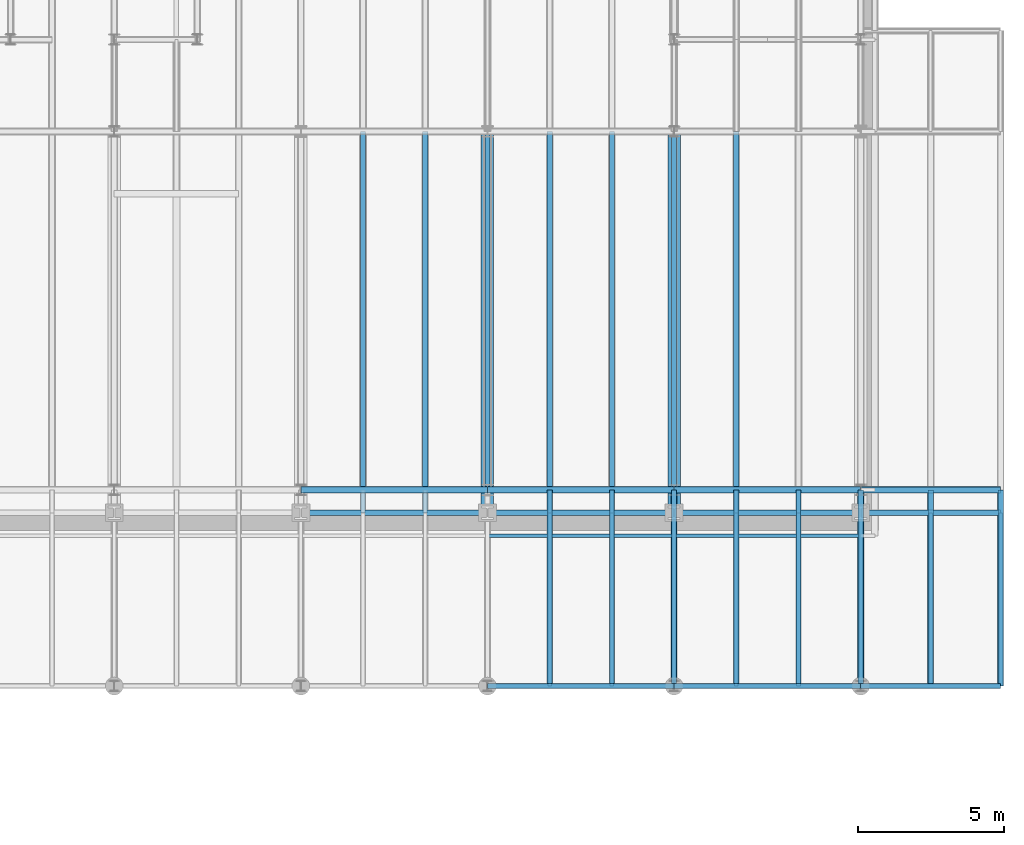
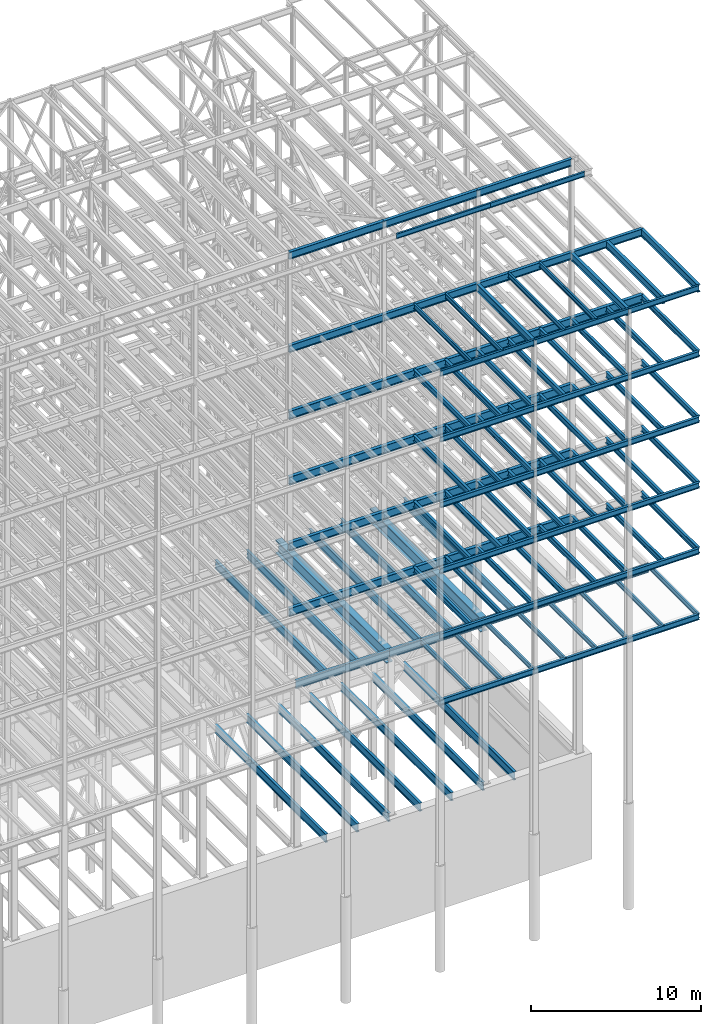
# One storey, part 139 of 150: 106 beams.
"""IFC2X3 building model written with IfcOpenShell, lengths in millimetres."""

from ifc_helpers import new_model, si_unit, frame, origin_with_axes, origin_2d_with_axis, place, context, subcontext, project, spatial, i_section, extrude, material, type_object, element, save


model = new_model("IFC2X3")

# Units and contexts
model_context = context("Model", 3, precision=1e-05, world=origin_with_axes())
body_context = subcontext(model_context, "Body", "Model", "MODEL_VIEW")
ifc_project = project(units=[si_unit("LENGTHUNIT", "METRE", prefix="MILLI"), si_unit("AREAUNIT", "SQUARE_METRE"), si_unit("VOLUMEUNIT", "CUBIC_METRE"), si_unit("MASSUNIT", "GRAM", prefix="KILO"), si_unit("TIMEUNIT", "SECOND"), si_unit("PLANEANGLEUNIT", "RADIAN"), si_unit("SOLIDANGLEUNIT", "STERADIAN"), si_unit("THERMODYNAMICTEMPERATUREUNIT", "DEGREE_CELSIUS"), si_unit("LUMINOUSINTENSITYUNIT", "LUMEN")], contexts=[model_context])

# Site, building, storey
site_placement = place(None, origin_with_axes())
site = spatial("IfcSite", under=ifc_project, at=site_placement, CompositionType="ELEMENT")
building_placement = place(site_placement, origin_with_axes())
building = spatial("IfcBuilding", under=site, at=building_placement, Name="Undefined", CompositionType="ELEMENT")
storey_placement = place(building_placement, origin_with_axes())
storey = spatial("IfcBuildingStorey", under=building, at=storey_placement, Name="Undefined", CompositionType="ELEMENT", Elevation=0.0)

# Beams
ifc_material = material(Name="STEEL/A992")
beam_type_1 = type_object("IfcBeamType", Name="W16X31", PredefinedType="NOTDEFINED")
beam_1_placement = place(storey_placement, frame((88595.2, 3454.4, 59005.7875), z_axis=(0.0, 0.0, 1.0), x_axis=(1.0, 0.0, 0.0)))
element("IfcBeam", 1, at=beam_1_placement, inside=storey, type_object=beam_type_1, material=ifc_material, Name="BEAM", ObjectType="W16X31", context=body_context, shape_type="SweptSolid", body=[
    extrude(i_section(OverallWidth=140.462, OverallDepth=403.225, WebThickness=6.3499, FlangeThickness=11.176, FilletRadius=17.399, at=origin_2d_with_axis()), frame((4800.60000000001, 0.0, 0.0), z_axis=(-1.0, 0.0, 0.0), x_axis=(0.0, -1.0, 0.0)), (0.0, 0.0, 1.0), 4800.60000000001),
])
beam_2_placement = place(storey_placement, frame((82194.4, 3454.4, 59005.7875), z_axis=(0.0, 0.0, 1.0), x_axis=(1.0, 0.0, 0.0)))
element("IfcBeam", 2, at=beam_2_placement, inside=storey, type_object=beam_type_1, material=ifc_material, Name="BEAM", ObjectType="W16X31", context=body_context, shape_type="SweptSolid", body=[
    extrude(i_section(OverallWidth=140.462, OverallDepth=403.225, WebThickness=6.3499, FlangeThickness=11.176, FilletRadius=17.399, at=origin_2d_with_axis()), frame((6400.80000000001, 0.0, 0.0), z_axis=(-1.0, 0.0, 0.0), x_axis=(0.0, -1.0, 0.0)), (0.0, 0.0, 1.0), 6400.80000000002),
])
beam_3_placement = place(storey_placement, frame((75793.6, 3454.4, 59005.7875), z_axis=(0.0, 0.0, 1.0), x_axis=(1.0, 0.0, 0.0)))
element("IfcBeam", 3, at=beam_3_placement, inside=storey, type_object=beam_type_1, material=ifc_material, Name="BEAM", ObjectType="W16X31", context=body_context, shape_type="SweptSolid", body=[
    extrude(i_section(OverallWidth=140.462, OverallDepth=403.225, WebThickness=6.3499, FlangeThickness=11.176, FilletRadius=17.399, at=origin_2d_with_axis()), frame((6400.80000000001, 0.0, 0.0), z_axis=(-1.0, 0.0, 0.0), x_axis=(0.0, -1.0, 0.0)), (0.0, 0.0, 1.0), 6400.79999999999),
])
beam_type_2 = type_object("IfcBeamType", Name="W24X68", PredefinedType="NOTDEFINED")
beam_4_placement = place(storey_placement, frame((88595.2, 10185.4, 54181.375), z_axis=(0.0, 0.0, 1.0), x_axis=(1.0, 0.0, 0.0)))
element("IfcBeam", 4, at=beam_4_placement, inside=storey, type_object=beam_type_2, material=ifc_material, Name="BEAM", ObjectType="W24X68", context=body_context, shape_type="SweptSolid", body=[
    extrude(i_section(OverallWidth=227.838, OverallDepth=603.25, WebThickness=11.1125, FlangeThickness=14.859, FilletRadius=23.2409, at=origin_2d_with_axis()), frame((4800.60000000001, 0.0, 0.0), z_axis=(-1.0, 0.0, 0.0), x_axis=(0.0, -1.0, 0.0)), (0.0, 0.0, 1.0), 4800.60000000001),
])
beam_5_placement = place(storey_placement, frame((82194.4, 10185.4, 54181.375), z_axis=(0.0, 0.0, 1.0), x_axis=(1.0, 0.0, 0.0)))
element("IfcBeam", 5, at=beam_5_placement, inside=storey, type_object=beam_type_2, material=ifc_material, Name="BEAM", ObjectType="W24X68", context=body_context, shape_type="SweptSolid", body=[
    extrude(i_section(OverallWidth=227.838, OverallDepth=603.25, WebThickness=11.1125, FlangeThickness=14.859, FilletRadius=23.2409, at=origin_2d_with_axis()), frame((6400.80000000001, 0.0, 0.0), z_axis=(-1.0, 0.0, 0.0), x_axis=(0.0, -1.0, 0.0)), (0.0, 0.0, 1.0), 6400.8),
])
beam_6_placement = place(storey_placement, frame((75793.6, 10185.4, 54181.375), z_axis=(0.0, 0.0, 1.0), x_axis=(1.0, 0.0, 0.0)))
element("IfcBeam", 6, at=beam_6_placement, inside=storey, type_object=beam_type_2, material=ifc_material, Name="BEAM", ObjectType="W24X68", context=body_context, shape_type="SweptSolid", body=[
    extrude(i_section(OverallWidth=227.838, OverallDepth=603.25, WebThickness=11.1125, FlangeThickness=14.859, FilletRadius=23.2409, at=origin_2d_with_axis()), frame((6400.80000000001, 0.0, 0.0), z_axis=(-1.0, 0.0, 0.0), x_axis=(0.0, -1.0, 0.0)), (0.0, 0.0, 1.0), 6400.79999999999),
])
for number, where, z_axis, x_axis, name in (
    (7, (69392.8, 10185.4, 54181.375), (0.0, 0.0, 1.0), (1.0, 0.0, 0.0), "BEAM"),
    (8, (82194.4, 10185.4, 49456.975), (0.0, 0.0, 1.0), (1.0, 0.0, 0.0), "BEAM"),
):
    element("IfcBeam", number, at=place(storey_placement, frame(where, z_axis=z_axis, x_axis=x_axis)), inside=storey, type_object=beam_type_2, material=ifc_material, Name=name, ObjectType="W24X68", context=body_context, shape_type="SweptSolid", body=[
        extrude(i_section(OverallWidth=227.838, OverallDepth=603.25, WebThickness=11.1125, FlangeThickness=14.859, FilletRadius=23.2409, at=origin_2d_with_axis()), frame((6400.80000000001, 0.0, 0.0), z_axis=(-1.0, 0.0, 0.0), x_axis=(0.0, -1.0, 0.0)), (0.0, 0.0, 1.0), 6400.8),
    ])
beam_7_placement = place(storey_placement, frame((75793.6, 10185.4, 49456.975), z_axis=(0.0, 0.0, 1.0), x_axis=(1.0, 0.0, 0.0)))
element("IfcBeam", 9, at=beam_7_placement, inside=storey, type_object=beam_type_2, material=ifc_material, Name="BEAM", ObjectType="W24X68", context=body_context, shape_type="SweptSolid", body=[
    extrude(i_section(OverallWidth=227.838, OverallDepth=603.25, WebThickness=11.1125, FlangeThickness=14.859, FilletRadius=23.2409, at=origin_2d_with_axis()), frame((6400.80000000001, 0.0, 0.0), z_axis=(-1.0, 0.0, 0.0), x_axis=(0.0, -1.0, 0.0)), (0.0, 0.0, 1.0), 6400.79999999999),
])
for number, where, z_axis, x_axis, name in (
    (10, (69392.8, 10185.4, 49456.975), (0.0, 0.0, 1.0), (1.0, 0.0, 0.0), "BEAM"),
    (11, (82194.4, 10185.4, 44732.575), (0.0, 0.0, 1.0), (1.0, 0.0, 0.0), "BEAM"),
):
    element("IfcBeam", number, at=place(storey_placement, frame(where, z_axis=z_axis, x_axis=x_axis)), inside=storey, type_object=beam_type_2, material=ifc_material, Name=name, ObjectType="W24X68", context=body_context, shape_type="SweptSolid", body=[
        extrude(i_section(OverallWidth=227.838, OverallDepth=603.25, WebThickness=11.1125, FlangeThickness=14.859, FilletRadius=23.2409, at=origin_2d_with_axis()), frame((6400.80000000001, 0.0, 0.0), z_axis=(-1.0, 0.0, 0.0), x_axis=(0.0, -1.0, 0.0)), (0.0, 0.0, 1.0), 6400.8),
    ])
beam_8_placement = place(storey_placement, frame((75793.6, 10185.4, 44732.575), z_axis=(0.0, 0.0, 1.0), x_axis=(1.0, 0.0, 0.0)))
element("IfcBeam", 12, at=beam_8_placement, inside=storey, type_object=beam_type_2, material=ifc_material, Name="BEAM", ObjectType="W24X68", context=body_context, shape_type="SweptSolid", body=[
    extrude(i_section(OverallWidth=227.838, OverallDepth=603.25, WebThickness=11.1125, FlangeThickness=14.859, FilletRadius=23.2409, at=origin_2d_with_axis()), frame((6400.80000000001, 0.0, 0.0), z_axis=(-1.0, 0.0, 0.0), x_axis=(0.0, -1.0, 0.0)), (0.0, 0.0, 1.0), 6400.79999999999),
])
for number, where, z_axis, x_axis, name in (
    (13, (69392.8, 10185.4, 44732.575), (0.0, 0.0, 1.0), (1.0, 0.0, 0.0), "BEAM"),
    (14, (82194.4, 10185.4, 40008.175), (0.0, 0.0, 1.0), (1.0, 0.0, 0.0), "BEAM"),
):
    element("IfcBeam", number, at=place(storey_placement, frame(where, z_axis=z_axis, x_axis=x_axis)), inside=storey, type_object=beam_type_2, material=ifc_material, Name=name, ObjectType="W24X68", context=body_context, shape_type="SweptSolid", body=[
        extrude(i_section(OverallWidth=227.838, OverallDepth=603.25, WebThickness=11.1125, FlangeThickness=14.859, FilletRadius=23.2409, at=origin_2d_with_axis()), frame((6400.80000000001, 0.0, 0.0), z_axis=(-1.0, 0.0, 0.0), x_axis=(0.0, -1.0, 0.0)), (0.0, 0.0, 1.0), 6400.8),
    ])
beam_9_placement = place(storey_placement, frame((75793.6, 10185.4, 40008.175), z_axis=(0.0, 0.0, 1.0), x_axis=(1.0, 0.0, 0.0)))
element("IfcBeam", 15, at=beam_9_placement, inside=storey, type_object=beam_type_2, material=ifc_material, Name="BEAM", ObjectType="W24X68", context=body_context, shape_type="SweptSolid", body=[
    extrude(i_section(OverallWidth=227.838, OverallDepth=603.25, WebThickness=11.1125, FlangeThickness=14.859, FilletRadius=23.2409, at=origin_2d_with_axis()), frame((6400.80000000001, 0.0, 0.0), z_axis=(-1.0, 0.0, 0.0), x_axis=(0.0, -1.0, 0.0)), (0.0, 0.0, 1.0), 6400.79999999999),
])
beam_10_placement = place(storey_placement, frame((69392.8, 10185.4, 40008.175), z_axis=(0.0, 0.0, 1.0), x_axis=(1.0, 0.0, 0.0)))
element("IfcBeam", 16, at=beam_10_placement, inside=storey, type_object=beam_type_2, material=ifc_material, Name="BEAM", ObjectType="W24X68", context=body_context, shape_type="SweptSolid", body=[
    extrude(i_section(OverallWidth=227.838, OverallDepth=603.25, WebThickness=11.1125, FlangeThickness=14.859, FilletRadius=23.2409, at=origin_2d_with_axis()), frame((6400.80000000001, 0.0, 0.0), z_axis=(-1.0, 0.0, 0.0), x_axis=(0.0, -1.0, 0.0)), (0.0, 0.0, 1.0), 6400.8),
])
beam_type_3 = type_object("IfcBeamType", Name="W14X22", PredefinedType="NOTDEFINED")
beam_11_placement = place(storey_placement, frame((82194.4, 8610.6, 65738.375), z_axis=(0.0, 0.0, 1.0), x_axis=(1.0, 0.0, 0.0)))
element("IfcBeam", 17, at=beam_11_placement, inside=storey, type_object=beam_type_3, material=ifc_material, Name="BEAM", ObjectType="W14X22", context=body_context, shape_type="SweptSolid", body=[
    extrude(i_section(OverallWidth=127.0, OverallDepth=349.25, WebThickness=6.3499, FlangeThickness=8.509, FilletRadius=18.4785, at=origin_2d_with_axis()), frame((6400.80000000001, 0.0, 0.0), z_axis=(-1.0, 0.0, 0.0), x_axis=(0.0, -1.0, 0.0)), (0.0, 0.0, 1.0), 6400.80000000002),
])
beam_12_placement = place(storey_placement, frame((75793.6, 8610.6, 65738.375), z_axis=(0.0, 0.0, 1.0), x_axis=(1.0, 0.0, 0.0)))
element("IfcBeam", 18, at=beam_12_placement, inside=storey, type_object=beam_type_3, material=ifc_material, Name="BEAM", ObjectType="W14X22", context=body_context, shape_type="SweptSolid", body=[
    extrude(i_section(OverallWidth=127.0, OverallDepth=349.25, WebThickness=6.3499, FlangeThickness=8.509, FilletRadius=18.4785, at=origin_2d_with_axis()), frame((6400.80000000001, 0.0, 0.0), z_axis=(-1.0, 0.0, 0.0), x_axis=(0.0, -1.0, 0.0)), (0.0, 0.0, 1.0), 6400.79999999999),
])
for number, where, z_axis, x_axis, name in (
    (19, (86461.6, 3454.4, 59032.775), (0.0, 0.0, 1.0), (0.0, 1.0, 0.0), "BEAM"),
    (20, (84328.0, 3454.4, 59032.775), (0.0, 0.0, 1.0), (0.0, 1.0, 0.0), "BEAM"),
    (21, (80060.8, 3454.4, 59032.775), (0.0, 0.0, 1.0), (0.0, 1.0, 0.0), "BEAM"),
    (22, (77927.2, 3454.4, 59032.775), (0.0, 0.0, 1.0), (0.0, 1.0, 0.0), "BEAM"),
):
    element("IfcBeam", number, at=place(storey_placement, frame(where, z_axis=z_axis, x_axis=x_axis)), inside=storey, type_object=beam_type_3, material=ifc_material, Name=name, ObjectType="W14X22", context=body_context, shape_type="SweptSolid", body=[
        extrude(i_section(OverallWidth=127.0, OverallDepth=349.25, WebThickness=6.3499, FlangeThickness=8.509, FilletRadius=18.4785, at=origin_2d_with_axis()), frame((6731.0, 0.0, 0.0), z_axis=(-1.0, 0.0, 0.0), x_axis=(0.0, -1.0, 0.0)), (0.0, 0.0, 1.0), 6731.0),
    ])
for number, where, z_axis, x_axis, name in (
    (23, (93395.8, 3454.4, 35410.775), (0.0, 0.0, 1.0), (0.0, 1.0, 0.0), "BEAM"),
    (24, (90995.5, 3454.4, 35410.775), (0.0, 0.0, 1.0), (0.0, 1.0, 0.0), "BEAM"),
    (25, (88595.2, 3454.4, 35410.775), (0.0, 0.0, 1.0), (0.0, 1.0, 0.0), "BEAM"),
    (26, (86461.6, 3454.4, 35410.775), (0.0, 0.0, 1.0), (0.0, 1.0, 0.0), "BEAM"),
    (27, (84328.0, 3454.4, 35410.775), (0.0, 0.0, 1.0), (0.0, 1.0, 0.0), "BEAM"),
    (28, (82194.4, 3454.4, 35410.775), (0.0, 0.0, 1.0), (0.0, 1.0, 0.0), "BEAM"),
    (29, (80060.8, 3454.4, 35410.775), (0.0, 0.0, 1.0), (0.0, 1.0, 0.0), "BEAM"),
    (30, (77927.2, 3454.4, 35410.775), (0.0, 0.0, 1.0), (0.0, 1.0, 0.0), "BEAM"),
):
    element("IfcBeam", number, at=place(storey_placement, frame(where, z_axis=z_axis, x_axis=x_axis)), inside=storey, type_object=beam_type_3, material=ifc_material, Name=name, ObjectType="W14X22", context=body_context, shape_type="SweptSolid", body=[
        extrude(i_section(OverallWidth=127.0, OverallDepth=349.25, WebThickness=6.3499, FlangeThickness=8.509, FilletRadius=18.4785, at=origin_2d_with_axis()), frame((5943.6, 0.0, 0.0), z_axis=(-1.0, 0.0, 0.0), x_axis=(0.0, -1.0, 0.0)), (0.0, 0.0, 1.0), 5943.6),
    ])
beam_type_4 = type_object("IfcBeamType", Name="W21X55", PredefinedType="NOTDEFINED")
beam_13_placement = place(storey_placement, frame((82194.4, 10185.4, 65649.475), z_axis=(0.0, 0.0, 1.0), x_axis=(1.0, 0.0, 0.0)))
element("IfcBeam", 31, at=beam_13_placement, inside=storey, type_object=beam_type_4, material=ifc_material, Name="BEAM", ObjectType="W21X55", context=body_context, shape_type="SweptSolid", body=[
    extrude(i_section(OverallWidth=208.788, OverallDepth=527.05, WebThickness=9.5, FlangeThickness=13.2588, FilletRadius=16.8624, at=origin_2d_with_axis()), frame((6400.80000000001, 0.0, 0.0), z_axis=(-1.0, 0.0, 0.0), x_axis=(0.0, -1.0, 0.0)), (0.0, 0.0, 1.0), 6400.80000000002),
])
beam_14_placement = place(storey_placement, frame((75793.6, 10185.4, 65649.475), z_axis=(0.0, 0.0, 1.0), x_axis=(1.0, 0.0, 0.0)))
element("IfcBeam", 32, at=beam_14_placement, inside=storey, type_object=beam_type_4, material=ifc_material, Name="BEAM", ObjectType="W21X55", context=body_context, shape_type="SweptSolid", body=[
    extrude(i_section(OverallWidth=208.788, OverallDepth=527.05, WebThickness=9.5, FlangeThickness=13.2588, FilletRadius=16.8624, at=origin_2d_with_axis()), frame((6400.80000000001, 0.0, 0.0), z_axis=(-1.0, 0.0, 0.0), x_axis=(0.0, -1.0, 0.0)), (0.0, 0.0, 1.0), 6400.79999999999),
])
beam_15_placement = place(storey_placement, frame((69392.8, 10185.4, 65649.475), z_axis=(0.0, 0.0, 1.0), x_axis=(1.0, 0.0, 0.0)))
element("IfcBeam", 33, at=beam_15_placement, inside=storey, type_object=beam_type_4, material=ifc_material, Name="BEAM", ObjectType="W21X55", context=body_context, shape_type="SweptSolid", body=[
    extrude(i_section(OverallWidth=208.788, OverallDepth=527.05, WebThickness=9.5, FlangeThickness=13.2588, FilletRadius=16.8624, at=origin_2d_with_axis()), frame((6400.80000000001, 0.0, 0.0), z_axis=(-1.0, 0.0, 0.0), x_axis=(0.0, -1.0, 0.0)), (0.0, 0.0, 1.0), 6400.80000000002),
])
beam_16_placement = place(storey_placement, frame((88595.2, 10185.4, 58943.875), z_axis=(0.0, 0.0, 1.0), x_axis=(1.0, 0.0, 0.0)))
element("IfcBeam", 34, at=beam_16_placement, inside=storey, type_object=beam_type_4, material=ifc_material, Name="BEAM", ObjectType="W21X55", context=body_context, shape_type="SweptSolid", body=[
    extrude(i_section(OverallWidth=208.788, OverallDepth=527.05, WebThickness=9.5, FlangeThickness=13.2588, FilletRadius=16.8624, at=origin_2d_with_axis()), frame((4800.60000000001, 0.0, 0.0), z_axis=(-1.0, 0.0, 0.0), x_axis=(0.0, -1.0, 0.0)), (0.0, 0.0, 1.0), 4800.60000000001),
])
for number, where, z_axis, x_axis, name in (
    (35, (93395.8, 3454.4, 58943.875), (0.0, 0.0, 1.0), (0.0, 1.0, 0.0), "BEAM"),
    (36, (90995.5, 3454.4, 58943.875), (0.0, 0.0, 1.0), (0.0, 1.0, 0.0), "BEAM"),
    (37, (88595.2, 3454.4, 58943.875), (0.0, 0.0, 1.0), (0.0, 1.0, 0.0), "BEAM"),
):
    element("IfcBeam", number, at=place(storey_placement, frame(where, z_axis=z_axis, x_axis=x_axis)), inside=storey, type_object=beam_type_4, material=ifc_material, Name=name, ObjectType="W21X55", context=body_context, shape_type="SweptSolid", body=[
        extrude(i_section(OverallWidth=208.788, OverallDepth=527.05, WebThickness=9.5, FlangeThickness=13.2588, FilletRadius=16.8624, at=origin_2d_with_axis()), frame((6731.0, 0.0, 0.0), z_axis=(-1.0, 0.0, 0.0), x_axis=(0.0, -1.0, 0.0)), (0.0, 0.0, 1.0), 6731.0),
    ])
beam_17_placement = place(storey_placement, frame((82194.4, 10185.4, 58943.875), z_axis=(0.0, 0.0, 1.0), x_axis=(1.0, 0.0, 0.0)))
element("IfcBeam", 38, at=beam_17_placement, inside=storey, type_object=beam_type_4, material=ifc_material, Name="BEAM", ObjectType="W21X55", context=body_context, shape_type="SweptSolid", body=[
    extrude(i_section(OverallWidth=208.788, OverallDepth=527.05, WebThickness=9.5, FlangeThickness=13.2588, FilletRadius=16.8624, at=origin_2d_with_axis()), frame((6400.80000000001, 0.0, 0.0), z_axis=(-1.0, 0.0, 0.0), x_axis=(0.0, -1.0, 0.0)), (0.0, 0.0, 1.0), 6400.80000000002),
])
beam_18_placement = place(storey_placement, frame((82194.4, 3454.4, 58943.875), z_axis=(0.0, 0.0, 1.0), x_axis=(0.0, 1.0, 0.0)))
element("IfcBeam", 39, at=beam_18_placement, inside=storey, type_object=beam_type_4, material=ifc_material, Name="BEAM", ObjectType="W21X55", context=body_context, shape_type="SweptSolid", body=[
    extrude(i_section(OverallWidth=208.788, OverallDepth=527.05, WebThickness=9.5, FlangeThickness=13.2588, FilletRadius=16.8624, at=origin_2d_with_axis()), frame((6731.0, 0.0, 0.0), z_axis=(-1.0, 0.0, 0.0), x_axis=(0.0, -1.0, 0.0)), (0.0, 0.0, 1.0), 6731.0),
])
beam_19_placement = place(storey_placement, frame((75793.6, 10185.4, 58943.875), z_axis=(0.0, 0.0, 1.0), x_axis=(1.0, 0.0, 0.0)))
element("IfcBeam", 40, at=beam_19_placement, inside=storey, type_object=beam_type_4, material=ifc_material, Name="BEAM", ObjectType="W21X55", context=body_context, shape_type="SweptSolid", body=[
    extrude(i_section(OverallWidth=208.788, OverallDepth=527.05, WebThickness=9.5, FlangeThickness=13.2588, FilletRadius=16.8624, at=origin_2d_with_axis()), frame((6400.80000000001, 0.0, 0.0), z_axis=(-1.0, 0.0, 0.0), x_axis=(0.0, -1.0, 0.0)), (0.0, 0.0, 1.0), 6400.79999999999),
])
beam_20_placement = place(storey_placement, frame((69392.8, 10185.4, 58943.875), z_axis=(0.0, 0.0, 1.0), x_axis=(1.0, 0.0, 0.0)))
element("IfcBeam", 41, at=beam_20_placement, inside=storey, type_object=beam_type_4, material=ifc_material, Name="BEAM", ObjectType="W21X55", context=body_context, shape_type="SweptSolid", body=[
    extrude(i_section(OverallWidth=208.788, OverallDepth=527.05, WebThickness=9.5, FlangeThickness=13.2588, FilletRadius=16.8624, at=origin_2d_with_axis()), frame((6400.80000000001, 0.0, 0.0), z_axis=(-1.0, 0.0, 0.0), x_axis=(0.0, -1.0, 0.0)), (0.0, 0.0, 1.0), 6400.80000000002),
])
beam_type_5 = type_object("IfcBeamType", Name="W24X55", PredefinedType="NOTDEFINED")
beam_21_placement = place(storey_placement, frame((88595.2, 9398.0, 35285.3625), z_axis=(0.0, 0.0, 1.0), x_axis=(1.0, 0.0, 0.0)))
element("IfcBeam", 42, at=beam_21_placement, inside=storey, type_object=beam_type_5, material=ifc_material, Name="BEAM", ObjectType="W24X55", context=body_context, shape_type="SweptSolid", body=[
    extrude(i_section(OverallWidth=178.054, OverallDepth=600.075, WebThickness=9.5249, FlangeThickness=12.827, FilletRadius=23.6854, at=origin_2d_with_axis()), frame((4800.60000000001, 0.0, 0.0), z_axis=(-1.0, 0.0, 0.0), x_axis=(0.0, -1.0, 0.0)), (0.0, 0.0, 1.0), 4800.60000000001),
])
beam_22_placement = place(storey_placement, frame((82194.4, 9398.0, 35285.3625), z_axis=(0.0, 0.0, 1.0), x_axis=(1.0, 0.0, 0.0)))
element("IfcBeam", 43, at=beam_22_placement, inside=storey, type_object=beam_type_5, material=ifc_material, Name="BEAM", ObjectType="W24X55", context=body_context, shape_type="SweptSolid", body=[
    extrude(i_section(OverallWidth=178.054, OverallDepth=600.075, WebThickness=9.5249, FlangeThickness=12.827, FilletRadius=23.6854, at=origin_2d_with_axis()), frame((6400.80000000001, 0.0, 0.0), z_axis=(-1.0, 0.0, 0.0), x_axis=(0.0, -1.0, 0.0)), (0.0, 0.0, 1.0), 6400.79999999999),
])
beam_23_placement = place(storey_placement, frame((75793.6, 9398.0, 35285.3625), z_axis=(0.0, 0.0, 1.0), x_axis=(1.0, 0.0, 0.0)))
element("IfcBeam", 44, at=beam_23_placement, inside=storey, type_object=beam_type_5, material=ifc_material, Name="BEAM", ObjectType="W24X55", context=body_context, shape_type="SweptSolid", body=[
    extrude(i_section(OverallWidth=178.054, OverallDepth=600.075, WebThickness=9.5249, FlangeThickness=12.827, FilletRadius=23.6854, at=origin_2d_with_axis()), frame((6400.80000000001, 0.0, 0.0), z_axis=(-1.0, 0.0, 0.0), x_axis=(0.0, -1.0, 0.0)), (0.0, 0.0, 1.0), 6400.8),
])
beam_24_placement = place(storey_placement, frame((69392.8, 9398.0, 35285.3625), z_axis=(0.0, 0.0, 1.0), x_axis=(1.0, 0.0, 0.0)))
element("IfcBeam", 45, at=beam_24_placement, inside=storey, type_object=beam_type_5, material=ifc_material, Name="BEAM", ObjectType="W24X55", context=body_context, shape_type="SweptSolid", body=[
    extrude(i_section(OverallWidth=178.054, OverallDepth=600.075, WebThickness=9.5249, FlangeThickness=12.827, FilletRadius=23.6854, at=origin_2d_with_axis()), frame((6400.80000000001, 0.0, 0.0), z_axis=(-1.0, 0.0, 0.0), x_axis=(0.0, -1.0, 0.0)), (0.0, 0.0, 1.0), 6400.79999999999),
])
beam_type_6 = type_object("IfcBeamType", Name="W16X36", PredefinedType="NOTDEFINED")
beam_25_placement = place(storey_placement, frame((88595.2, 3454.4, 54281.3875), z_axis=(0.0, 0.0, 1.0), x_axis=(1.0, 0.0, 0.0)))
element("IfcBeam", 46, at=beam_25_placement, inside=storey, type_object=beam_type_6, material=ifc_material, Name="BEAM", ObjectType="W16X36", context=body_context, shape_type="SweptSolid", body=[
    extrude(i_section(OverallWidth=177.8, OverallDepth=403.225, WebThickness=7.9375, FlangeThickness=10.922, FilletRadius=17.6529, at=origin_2d_with_axis()), frame((4800.60000000001, 0.0, 0.0), z_axis=(-1.0, 0.0, 0.0), x_axis=(0.0, -1.0, 0.0)), (0.0, 0.0, 1.0), 4800.60000000001),
])
for number, where, z_axis, x_axis, name in (
    (47, (82194.4, 3454.4, 54281.3875), (0.0, 0.0, 1.0), (1.0, 0.0, 0.0), "BEAM"),
    (48, (75793.6, 3454.4, 54281.3875), (0.0, 0.0, 1.0), (1.0, 0.0, 0.0), "BEAM"),
):
    element("IfcBeam", number, at=place(storey_placement, frame(where, z_axis=z_axis, x_axis=x_axis)), inside=storey, type_object=beam_type_6, material=ifc_material, Name=name, ObjectType="W16X36", context=body_context, shape_type="SweptSolid", body=[
        extrude(i_section(OverallWidth=177.8, OverallDepth=403.225, WebThickness=7.9375, FlangeThickness=10.922, FilletRadius=17.6529, at=origin_2d_with_axis()), frame((6400.80000000001, 0.0, 0.0), z_axis=(-1.0, 0.0, 0.0), x_axis=(0.0, -1.0, 0.0)), (0.0, 0.0, 1.0), 6400.8),
    ])
for number, where, z_axis, x_axis, name in (
    (49, (93395.8, 3454.4, 54281.3875), (0.0, 0.0, 1.0), (0.0, 1.0, 0.0), "BEAM"),
    (50, (90995.5, 3454.4, 54281.3875), (0.0, 0.0, 1.0), (0.0, 1.0, 0.0), "BEAM"),
    (51, (88595.2, 3454.4, 54281.3875), (0.0, 0.0, 1.0), (0.0, 1.0, 0.0), "BEAM"),
    (52, (86461.6, 3454.4, 54281.3875), (0.0, 0.0, 1.0), (0.0, 1.0, 0.0), "BEAM"),
    (53, (84328.0, 3454.4, 54281.3875), (0.0, 0.0, 1.0), (0.0, 1.0, 0.0), "BEAM"),
    (54, (82194.4, 3454.4, 54281.3875), (0.0, 0.0, 1.0), (0.0, 1.0, 0.0), "BEAM"),
    (55, (80060.8, 3454.4, 54281.3875), (0.0, 0.0, 1.0), (0.0, 1.0, 0.0), "BEAM"),
    (56, (77927.2, 3454.4, 54281.3875), (0.0, 0.0, 1.0), (0.0, 1.0, 0.0), "BEAM"),
):
    element("IfcBeam", number, at=place(storey_placement, frame(where, z_axis=z_axis, x_axis=x_axis)), inside=storey, type_object=beam_type_6, material=ifc_material, Name=name, ObjectType="W16X36", context=body_context, shape_type="SweptSolid", body=[
        extrude(i_section(OverallWidth=177.8, OverallDepth=403.225, WebThickness=7.9375, FlangeThickness=10.922, FilletRadius=17.6529, at=origin_2d_with_axis()), frame((6731.0, 0.0, 0.0), z_axis=(-1.0, 0.0, 0.0), x_axis=(0.0, -1.0, 0.0)), (0.0, 0.0, 1.0), 6731.0),
    ])
beam_26_placement = place(storey_placement, frame((88595.2, 3454.4, 49556.9875), z_axis=(0.0, 0.0, 1.0), x_axis=(1.0, 0.0, 0.0)))
element("IfcBeam", 57, at=beam_26_placement, inside=storey, type_object=beam_type_6, material=ifc_material, Name="BEAM", ObjectType="W16X36", context=body_context, shape_type="SweptSolid", body=[
    extrude(i_section(OverallWidth=177.8, OverallDepth=403.225, WebThickness=7.9375, FlangeThickness=10.922, FilletRadius=17.6529, at=origin_2d_with_axis()), frame((4800.60000000001, 0.0, 0.0), z_axis=(-1.0, 0.0, 0.0), x_axis=(0.0, -1.0, 0.0)), (0.0, 0.0, 1.0), 4800.60000000001),
])
for number, where, z_axis, x_axis, name in (
    (58, (82194.4, 3454.4, 49556.9875), (0.0, 0.0, 1.0), (1.0, 0.0, 0.0), "BEAM"),
    (59, (75793.6, 3454.4, 49556.9875), (0.0, 0.0, 1.0), (1.0, 0.0, 0.0), "BEAM"),
):
    element("IfcBeam", number, at=place(storey_placement, frame(where, z_axis=z_axis, x_axis=x_axis)), inside=storey, type_object=beam_type_6, material=ifc_material, Name=name, ObjectType="W16X36", context=body_context, shape_type="SweptSolid", body=[
        extrude(i_section(OverallWidth=177.8, OverallDepth=403.225, WebThickness=7.9375, FlangeThickness=10.922, FilletRadius=17.6529, at=origin_2d_with_axis()), frame((6400.80000000001, 0.0, 0.0), z_axis=(-1.0, 0.0, 0.0), x_axis=(0.0, -1.0, 0.0)), (0.0, 0.0, 1.0), 6400.8),
    ])
for number, where, z_axis, x_axis, name in (
    (60, (93395.8, 3454.4, 49556.9875), (0.0, 0.0, 1.0), (0.0, 1.0, 0.0), "BEAM"),
    (61, (90995.5, 3454.4, 49556.9875), (0.0, 0.0, 1.0), (0.0, 1.0, 0.0), "BEAM"),
    (62, (88595.2, 3454.4, 49556.9875), (0.0, 0.0, 1.0), (0.0, 1.0, 0.0), "BEAM"),
    (63, (86461.6, 3454.4, 49556.9875), (0.0, 0.0, 1.0), (0.0, 1.0, 0.0), "BEAM"),
    (64, (84328.0, 3454.4, 49556.9875), (0.0, 0.0, 1.0), (0.0, 1.0, 0.0), "BEAM"),
    (65, (82194.4, 3454.4, 49556.9875), (0.0, 0.0, 1.0), (0.0, 1.0, 0.0), "BEAM"),
    (66, (80060.8, 3454.4, 49556.9875), (0.0, 0.0, 1.0), (0.0, 1.0, 0.0), "BEAM"),
    (67, (77927.2, 3454.4, 49556.9875), (0.0, 0.0, 1.0), (0.0, 1.0, 0.0), "BEAM"),
):
    element("IfcBeam", number, at=place(storey_placement, frame(where, z_axis=z_axis, x_axis=x_axis)), inside=storey, type_object=beam_type_6, material=ifc_material, Name=name, ObjectType="W16X36", context=body_context, shape_type="SweptSolid", body=[
        extrude(i_section(OverallWidth=177.8, OverallDepth=403.225, WebThickness=7.9375, FlangeThickness=10.922, FilletRadius=17.6529, at=origin_2d_with_axis()), frame((6731.0, 0.0, 0.0), z_axis=(-1.0, 0.0, 0.0), x_axis=(0.0, -1.0, 0.0)), (0.0, 0.0, 1.0), 6731.0),
    ])
beam_27_placement = place(storey_placement, frame((88595.2, 3454.4, 44832.5875), z_axis=(0.0, 0.0, 1.0), x_axis=(1.0, 0.0, 0.0)))
element("IfcBeam", 68, at=beam_27_placement, inside=storey, type_object=beam_type_6, material=ifc_material, Name="BEAM", ObjectType="W16X36", context=body_context, shape_type="SweptSolid", body=[
    extrude(i_section(OverallWidth=177.8, OverallDepth=403.225, WebThickness=7.9375, FlangeThickness=10.922, FilletRadius=17.6529, at=origin_2d_with_axis()), frame((4800.60000000001, 0.0, 0.0), z_axis=(-1.0, 0.0, 0.0), x_axis=(0.0, -1.0, 0.0)), (0.0, 0.0, 1.0), 4800.60000000001),
])
for number, where, z_axis, x_axis, name in (
    (69, (82194.4, 3454.4, 44832.5875), (0.0, 0.0, 1.0), (1.0, 0.0, 0.0), "BEAM"),
    (70, (75793.6, 3454.4, 44832.5875), (0.0, 0.0, 1.0), (1.0, 0.0, 0.0), "BEAM"),
):
    element("IfcBeam", number, at=place(storey_placement, frame(where, z_axis=z_axis, x_axis=x_axis)), inside=storey, type_object=beam_type_6, material=ifc_material, Name=name, ObjectType="W16X36", context=body_context, shape_type="SweptSolid", body=[
        extrude(i_section(OverallWidth=177.8, OverallDepth=403.225, WebThickness=7.9375, FlangeThickness=10.922, FilletRadius=17.6529, at=origin_2d_with_axis()), frame((6400.80000000001, 0.0, 0.0), z_axis=(-1.0, 0.0, 0.0), x_axis=(0.0, -1.0, 0.0)), (0.0, 0.0, 1.0), 6400.8),
    ])
for number, where, z_axis, x_axis, name in (
    (71, (93395.8, 3454.4, 44832.5875), (0.0, 0.0, 1.0), (0.0, 1.0, 0.0), "BEAM"),
    (72, (90995.5, 3454.4, 44832.5875), (0.0, 0.0, 1.0), (0.0, 1.0, 0.0), "BEAM"),
    (73, (88595.2, 3454.4, 44832.5875), (0.0, 0.0, 1.0), (0.0, 1.0, 0.0), "BEAM"),
    (74, (86461.6, 3454.4, 44832.5875), (0.0, 0.0, 1.0), (0.0, 1.0, 0.0), "BEAM"),
    (75, (84328.0, 3454.4, 44832.5875), (0.0, 0.0, 1.0), (0.0, 1.0, 0.0), "BEAM"),
    (76, (82194.4, 3454.4, 44832.5875), (0.0, 0.0, 1.0), (0.0, 1.0, 0.0), "BEAM"),
    (77, (80060.8, 3454.4, 44832.5875), (0.0, 0.0, 1.0), (0.0, 1.0, 0.0), "BEAM"),
    (78, (77927.2, 3454.4, 44832.5875), (0.0, 0.0, 1.0), (0.0, 1.0, 0.0), "BEAM"),
):
    element("IfcBeam", number, at=place(storey_placement, frame(where, z_axis=z_axis, x_axis=x_axis)), inside=storey, type_object=beam_type_6, material=ifc_material, Name=name, ObjectType="W16X36", context=body_context, shape_type="SweptSolid", body=[
        extrude(i_section(OverallWidth=177.8, OverallDepth=403.225, WebThickness=7.9375, FlangeThickness=10.922, FilletRadius=17.6529, at=origin_2d_with_axis()), frame((6731.0, 0.0, 0.0), z_axis=(-1.0, 0.0, 0.0), x_axis=(0.0, -1.0, 0.0)), (0.0, 0.0, 1.0), 6731.0),
    ])
beam_28_placement = place(storey_placement, frame((88595.2, 3454.4, 40108.1875), z_axis=(0.0, 0.0, 1.0), x_axis=(1.0, 0.0, 0.0)))
element("IfcBeam", 79, at=beam_28_placement, inside=storey, type_object=beam_type_6, material=ifc_material, Name="BEAM", ObjectType="W16X36", context=body_context, shape_type="SweptSolid", body=[
    extrude(i_section(OverallWidth=177.8, OverallDepth=403.225, WebThickness=7.9375, FlangeThickness=10.922, FilletRadius=17.6529, at=origin_2d_with_axis()), frame((4800.60000000001, 0.0, 0.0), z_axis=(-1.0, 0.0, 0.0), x_axis=(0.0, -1.0, 0.0)), (0.0, 0.0, 1.0), 4800.60000000001),
])
for number, where, z_axis, x_axis, name in (
    (80, (82194.4, 3454.4, 40108.1875), (0.0, 0.0, 1.0), (1.0, 0.0, 0.0), "BEAM"),
    (81, (75793.6, 3454.4, 40108.1875), (0.0, 0.0, 1.0), (1.0, 0.0, 0.0), "BEAM"),
):
    element("IfcBeam", number, at=place(storey_placement, frame(where, z_axis=z_axis, x_axis=x_axis)), inside=storey, type_object=beam_type_6, material=ifc_material, Name=name, ObjectType="W16X36", context=body_context, shape_type="SweptSolid", body=[
        extrude(i_section(OverallWidth=177.8, OverallDepth=403.225, WebThickness=7.9375, FlangeThickness=10.922, FilletRadius=17.6529, at=origin_2d_with_axis()), frame((6400.80000000001, 0.0, 0.0), z_axis=(-1.0, 0.0, 0.0), x_axis=(0.0, -1.0, 0.0)), (0.0, 0.0, 1.0), 6400.8),
    ])
for number, where, z_axis, x_axis, name in (
    (82, (93395.8, 3454.4, 40108.1875), (0.0, 0.0, 1.0), (0.0, 1.0, 0.0), "BEAM"),
    (83, (90995.5, 3454.4, 40108.1875), (0.0, 0.0, 1.0), (0.0, 1.0, 0.0), "BEAM"),
    (84, (88595.2, 3454.4, 40108.1875), (0.0, 0.0, 1.0), (0.0, 1.0, 0.0), "BEAM"),
    (85, (86461.6, 3454.4, 40108.1875), (0.0, 0.0, 1.0), (0.0, 1.0, 0.0), "BEAM"),
    (86, (84328.0, 3454.4, 40108.1875), (0.0, 0.0, 1.0), (0.0, 1.0, 0.0), "BEAM"),
    (87, (82194.4, 3454.4, 40108.1875), (0.0, 0.0, 1.0), (0.0, 1.0, 0.0), "BEAM"),
    (88, (80060.8, 3454.4, 40108.1875), (0.0, 0.0, 1.0), (0.0, 1.0, 0.0), "BEAM"),
    (89, (77927.2, 3454.4, 40108.1875), (0.0, 0.0, 1.0), (0.0, 1.0, 0.0), "BEAM"),
):
    element("IfcBeam", number, at=place(storey_placement, frame(where, z_axis=z_axis, x_axis=x_axis)), inside=storey, type_object=beam_type_6, material=ifc_material, Name=name, ObjectType="W16X36", context=body_context, shape_type="SweptSolid", body=[
        extrude(i_section(OverallWidth=177.8, OverallDepth=403.225, WebThickness=7.9375, FlangeThickness=10.922, FilletRadius=17.6529, at=origin_2d_with_axis()), frame((6731.0, 0.0, 0.0), z_axis=(-1.0, 0.0, 0.0), x_axis=(0.0, -1.0, 0.0)), (0.0, 0.0, 1.0), 6731.0),
    ])
beam_29_placement = place(storey_placement, frame((88595.2, 3454.4, 35383.7875), z_axis=(0.0, 0.0, 1.0), x_axis=(1.0, 0.0, 0.0)))
element("IfcBeam", 90, at=beam_29_placement, inside=storey, type_object=beam_type_6, material=ifc_material, Name="BEAM", ObjectType="W16X36", context=body_context, shape_type="SweptSolid", body=[
    extrude(i_section(OverallWidth=177.8, OverallDepth=403.225, WebThickness=7.9375, FlangeThickness=10.922, FilletRadius=17.6529, at=origin_2d_with_axis()), frame((4800.60000000001, 0.0, 0.0), z_axis=(-1.0, 0.0, 0.0), x_axis=(0.0, -1.0, 0.0)), (0.0, 0.0, 1.0), 4800.60000000001),
])
for number, where, z_axis, x_axis, name in (
    (91, (82194.4, 3454.4, 35383.7875), (0.0, 0.0, 1.0), (1.0, 0.0, 0.0), "BEAM"),
    (92, (75793.6, 3454.4, 35383.7875), (0.0, 0.0, 1.0), (1.0, 0.0, 0.0), "BEAM"),
):
    element("IfcBeam", number, at=place(storey_placement, frame(where, z_axis=z_axis, x_axis=x_axis)), inside=storey, type_object=beam_type_6, material=ifc_material, Name=name, ObjectType="W16X36", context=body_context, shape_type="SweptSolid", body=[
        extrude(i_section(OverallWidth=177.8, OverallDepth=403.225, WebThickness=7.9375, FlangeThickness=10.922, FilletRadius=17.6529, at=origin_2d_with_axis()), frame((6400.80000000001, 0.0, 0.0), z_axis=(-1.0, 0.0, 0.0), x_axis=(0.0, -1.0, 0.0)), (0.0, 0.0, 1.0), 6400.8),
    ])
beam_type_7 = type_object("IfcBeamType", Name="W24X62", PredefinedType="NOTDEFINED")
for number, where, z_axis, x_axis, name in (
    (93, (84327.99935992, 9398.0, 35283.775), (0.0, 0.0, 1.0), (0.0, 1.0, 0.0), "BEAM"),
    (94, (80060.79935992, 9398.0, 35283.775), (0.0, 0.0, 1.0), (0.0, 1.0, 0.0), "BEAM"),
    (95, (77927.19935992, 9398.0, 35283.775), (0.0, 0.0, 1.0), (0.0, 1.0, 0.0), "BEAM"),
    (96, (73659.99935992, 9398.0, 35283.775), (0.0, 0.0, 1.0), (0.0, 1.0, 0.0), "BEAM"),
    (97, (71526.39935992, 9398.0, 35283.775), (0.0, 0.0, 1.0), (0.0, 1.0, 0.0), "BEAM"),
    (98, (84328.0, 9398.0, 23472.775), (0.0, 0.0, 1.0), (0.0, 1.0, 0.0), "BEAM"),
    (99, (82194.4, 9398.0, 23472.775), (0.0, 0.0, 1.0), (0.0, 1.0, 0.0), "BEAM"),
    (100, (80060.8, 9398.0, 23472.775), (0.0, 0.0, 1.0), (0.0, 1.0, 0.0), "BEAM"),
    (101, (77927.2, 9398.0, 23472.775), (0.0, 0.0, 1.0), (0.0, 1.0, 0.0), "BEAM"),
    (102, (75793.6, 9398.0, 23472.775), (0.0, 0.0, 1.0), (0.0, 1.0, 0.0), "BEAM"),
    (103, (73660.0, 9398.0, 23472.775), (0.0, 0.0, 1.0), (0.0, 1.0, 0.0), "BEAM"),
    (104, (71526.4, 9398.0, 23472.775), (0.0, 0.0, 1.0), (0.0, 1.0, 0.0), "BEAM"),
):
    element("IfcBeam", number, at=place(storey_placement, frame(where, z_axis=z_axis, x_axis=x_axis)), inside=storey, type_object=beam_type_7, material=ifc_material, Name=name, ObjectType="W24X62", context=body_context, shape_type="SweptSolid", body=[
        extrude(i_section(OverallWidth=177.8, OverallDepth=603.25, WebThickness=11.1125, FlangeThickness=14.986, FilletRadius=23.114, at=origin_2d_with_axis()), frame((13081.0, 0.0, 0.0), z_axis=(-1.0, 0.0, 0.0), x_axis=(0.0, -1.0, 0.0)), (0.0, 0.0, 1.0), 13081.0),
    ])
beam_type_8 = type_object("IfcBeamType", Name="W36X395", PredefinedType="NOTDEFINED")
for number, where, z_axis, x_axis, name in (
    (105, (82194.4, 9398.0, 35098.0375), (0.0, 0.0, 1.0), (0.0, 1.0, 0.0), "BEAM"),
    (106, (75793.6, 9398.0, 35098.0375), (0.0, 0.0, 1.0), (0.0, 1.0, 0.0), "BEAM"),
):
    element("IfcBeam", number, at=place(storey_placement, frame(where, z_axis=z_axis, x_axis=x_axis)), inside=storey, type_object=beam_type_8, material=ifc_material, Name=name, ObjectType="W36X395", context=body_context, shape_type="SweptSolid", body=[
        extrude(i_section(OverallWidth=428.625, OverallDepth=974.725, WebThickness=30.988, FlangeThickness=55.88, FilletRadius=31.4324, at=origin_2d_with_axis()), frame((13081.0, 0.0, 0.0), z_axis=(-1.0, 0.0, 0.0), x_axis=(0.0, -1.0, 0.0)), (0.0, 0.0, 1.0), 13081.0),
    ])

save(model, "model.ifc")
